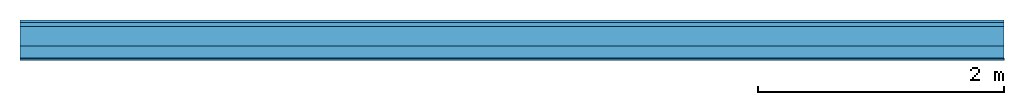
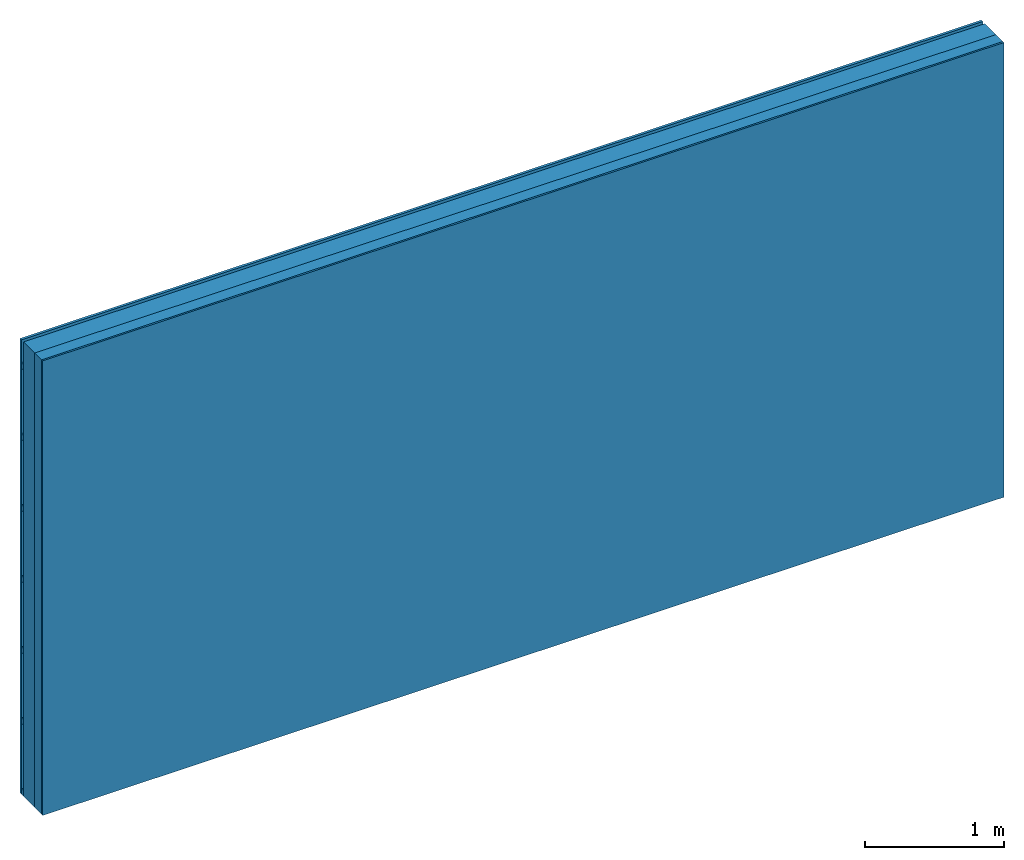
# One storey: 3 plates, 2 members, 1 element without a shape of its own.
"""IFC4 building model written with IfcOpenShell, lengths in metres."""

from ifc_helpers import new_model, si_unit, derived_unit, direction, frame, frame_2d, origin, origin_with_axes, place, context, project, spatial, rectangle, extrude, material, layer, layer_set, type_object, element, aggregate, save


model = new_model("IFC4")

# Units and contexts
plan_context = context("Plan", 3, precision=1e-05, world=origin(), true_north=direction((0.0, 1.0)))
model_context = context("Model", 3, precision=1e-05, world=origin(), true_north=direction((0.0, 1.0)))
ifc_project = project(units=[si_unit("LENGTHUNIT", "METRE"), derived_unit("SOUNDPRESSUREUNIT", [(si_unit("PRESSUREUNIT", "PASCAL", prefix="MICRO"), 0)]), si_unit("ENERGYUNIT", "JOULE", prefix="MEGA"), si_unit("MASSUNIT", "GRAM", prefix="KILO"), derived_unit("THERMALTRANSMITTANCEUNIT", [(si_unit("POWERUNIT", "WATT"), 1), (si_unit("AREAUNIT", "SQUARE_METRE"), -1), (si_unit("THERMODYNAMICTEMPERATUREUNIT", "KELVIN"), -1)]), derived_unit("AREADENSITYUNIT", [(si_unit("MASSUNIT", "GRAM", prefix="KILO"), 1), (si_unit("AREAUNIT", "SQUARE_METRE"), -1)]), derived_unit("USERDEFINED", [(si_unit("ENERGYUNIT", "JOULE", prefix="MEGA"), 1), (si_unit("AREAUNIT", "SQUARE_METRE"), -1)])], contexts=[plan_context, model_context])

# Site, building, storey
site = spatial("IfcSite", under=ifc_project)
building_placement = place(None, origin())
building = spatial("IfcBuilding", under=site, at=building_placement)
storey_placement = place(building_placement, origin())
storey = spatial("IfcBuildingStorey", under=building, at=storey_placement)

# Wall, members, plates
ifc_material_1 = material(Name="Wood cladding horizontal, closed")
ifc_layer_1 = layer(ifc_material_1, 0.022, Name="Cover 1st layer")
ifc_layer_2 = layer(None, 0.03, Name="Battens / profiles (ventilation)")
ifc_material_2 = material(Category="10.009")
ifc_layer_3 = layer(ifc_material_2, 0.16, Name="outside 2nd layer")
ifc_material_3 = material(Name="of the art")
ifc_layer_4 = layer(ifc_material_3, 0.0, Name="Bond")
ifc_layer_5 = layer(None, 0.1, Name="Support")
ifc_layer_6 = layer(ifc_material_3, 0.0, Name="Bond")
ifc_material_4 = material(Category="03.007")
ifc_layer_7 = layer(ifc_material_4, 0.015, Name="1st layer")
ifc_layer_set = layer_set([ifc_layer_1, ifc_layer_2, ifc_layer_3, ifc_layer_4, ifc_layer_5, ifc_layer_6, ifc_layer_7])
wall_type = type_object("IfcWallType", Name="D0935", PredefinedType="NOTDEFINED", material=ifc_layer_set)
wall_placement = place(None, frame((0.0, 0.0, 0.0), z_axis=(0.0, -1.0, 0.0), x_axis=(1.0, 0.0, 0.0)))
wall = element("IfcWall", 1, at=wall_placement, inside=storey, type_object=wall_type, material=ifc_layer_set, Name="Wall #1")
ifc_material_5 = material()
member_1_placement = place(wall_placement, origin())
member_1 = element("IfcMember", 2, at=member_1_placement, material=ifc_material_5, Name="Battens / profiles (ventilation)", context=plan_context, shape_type="SweptSolid", body=[
    extrude(rectangle(XDim=0.05, YDim=0.03, at=frame_2d((0.025, 0.015), x_axis=(1.0, 0.0))), frame((0.0, 0.0, 0.022), z_axis=(1.0, 0.0, 0.0), x_axis=(0.0, 1.0, 0.0)), (0.0, 0.0, 1.0), 8.0),
    extrude(rectangle(XDim=0.05, YDim=0.03, at=frame_2d((0.025, 0.015), x_axis=(1.0, 0.0))), frame((0.0, 0.625, 0.022), z_axis=(1.0, 0.0, 0.0), x_axis=(0.0, 1.0, 0.0)), (0.0, 0.0, 1.0), 8.0),
    extrude(rectangle(XDim=0.05, YDim=0.03, at=frame_2d((0.025, 0.015), x_axis=(1.0, 0.0))), frame((0.0, 1.25, 0.022), z_axis=(1.0, 0.0, 0.0), x_axis=(0.0, 1.0, 0.0)), (0.0, 0.0, 1.0), 8.0),
    extrude(rectangle(XDim=0.05, YDim=0.03, at=frame_2d((0.025, 0.015), x_axis=(1.0, 0.0))), frame((0.0, 1.875, 0.022), z_axis=(1.0, 0.0, 0.0), x_axis=(0.0, 1.0, 0.0)), (0.0, 0.0, 1.0), 8.0),
    extrude(rectangle(XDim=0.05, YDim=0.03, at=frame_2d((0.025, 0.015), x_axis=(1.0, 0.0))), frame((0.0, 2.5, 0.022), z_axis=(1.0, 0.0, 0.0), x_axis=(0.0, 1.0, 0.0)), (0.0, 0.0, 1.0), 8.0),
    extrude(rectangle(XDim=0.05, YDim=0.03, at=frame_2d((0.025, 0.015), x_axis=(1.0, 0.0))), frame((0.0, 3.125, 0.022), z_axis=(1.0, 0.0, 0.0), x_axis=(0.0, 1.0, 0.0)), (0.0, 0.0, 1.0), 8.0),
    extrude(rectangle(XDim=0.05, YDim=0.03, at=frame_2d((0.025, 0.015), x_axis=(1.0, 0.0))), frame((0.0, 3.75, 0.022), z_axis=(1.0, 0.0, 0.0), x_axis=(0.0, 1.0, 0.0)), (0.0, 0.0, 1.0), 8.0),
])
ifc_material_6 = material()
member_2_placement = place(wall_placement, origin())
member_2 = element("IfcMember", 3, at=member_2_placement, material=ifc_material_6, Name="Support", context=plan_context, shape_type="SweptSolid", body=[
    extrude(rectangle(XDim=1.0, YDim=0.1, at=frame_2d((0.5, 0.05), x_axis=(1.0, 0.0))), frame((0.0, 4.0, 0.212), z_axis=(0.0, -1.0, 0.0), x_axis=(1.0, 0.0, 0.0)), (0.0, 0.0, 1.0), 4.0),
    extrude(rectangle(XDim=1.0, YDim=0.1, at=frame_2d((0.5, 0.05), x_axis=(1.0, 0.0))), frame((1.0, 4.0, 0.212), z_axis=(0.0, -1.0, 0.0), x_axis=(1.0, 0.0, 0.0)), (0.0, 0.0, 1.0), 4.0),
    extrude(rectangle(XDim=1.0, YDim=0.1, at=frame_2d((0.5, 0.05), x_axis=(1.0, 0.0))), frame((2.0, 4.0, 0.212), z_axis=(0.0, -1.0, 0.0), x_axis=(1.0, 0.0, 0.0)), (0.0, 0.0, 1.0), 4.0),
    extrude(rectangle(XDim=1.0, YDim=0.1, at=frame_2d((0.5, 0.05), x_axis=(1.0, 0.0))), frame((3.0, 4.0, 0.212), z_axis=(0.0, -1.0, 0.0), x_axis=(1.0, 0.0, 0.0)), (0.0, 0.0, 1.0), 4.0),
    extrude(rectangle(XDim=1.0, YDim=0.1, at=frame_2d((0.5, 0.05), x_axis=(1.0, 0.0))), frame((4.0, 4.0, 0.212), z_axis=(0.0, -1.0, 0.0), x_axis=(1.0, 0.0, 0.0)), (0.0, 0.0, 1.0), 4.0),
    extrude(rectangle(XDim=1.0, YDim=0.1, at=frame_2d((0.5, 0.05), x_axis=(1.0, 0.0))), frame((5.0, 4.0, 0.212), z_axis=(0.0, -1.0, 0.0), x_axis=(1.0, 0.0, 0.0)), (0.0, 0.0, 1.0), 4.0),
    extrude(rectangle(XDim=1.0, YDim=0.1, at=frame_2d((0.5, 0.05), x_axis=(1.0, 0.0))), frame((6.0, 4.0, 0.212), z_axis=(0.0, -1.0, 0.0), x_axis=(1.0, 0.0, 0.0)), (0.0, 0.0, 1.0), 4.0),
    extrude(rectangle(XDim=1.0, YDim=0.1, at=frame_2d((0.5, 0.05), x_axis=(1.0, 0.0))), frame((7.0, 4.0, 0.212), z_axis=(0.0, -1.0, 0.0), x_axis=(1.0, 0.0, 0.0)), (0.0, 0.0, 1.0), 4.0),
])
plate_1_placement = place(wall_placement, origin())
plate_1 = element("IfcPlate", 4, at=plate_1_placement, material=ifc_material_1, Name="Cover 1st layer", context=plan_context, shape_type="SweptSolid", body=[
    extrude(rectangle(XDim=8.0, YDim=4.0, at=frame_2d((4.0, 2.0), x_axis=(1.0, 0.0))), origin_with_axes(), (0.0, 0.0, 1.0), 0.022),
])
plate_2_placement = place(wall_placement, origin())
plate_2 = element("IfcPlate", 5, at=plate_2_placement, material=ifc_material_2, Name="outside 2nd layer", context=plan_context, shape_type="SweptSolid", body=[
    extrude(rectangle(XDim=8.0, YDim=4.0, at=frame_2d((4.0, 2.0), x_axis=(1.0, 0.0))), frame((0.0, 0.0, 0.052), z_axis=(0.0, 0.0, 1.0), x_axis=(1.0, 0.0, 0.0)), (0.0, 0.0, 1.0), 0.16),
])
plate_3_placement = place(wall_placement, origin())
plate_3 = element("IfcPlate", 6, at=plate_3_placement, material=ifc_material_4, Name="1st layer", context=plan_context, shape_type="SweptSolid", body=[
    extrude(rectangle(XDim=8.0, YDim=4.0, at=frame_2d((4.0, 2.0), x_axis=(1.0, 0.0))), frame((0.0, 0.0, 0.312), z_axis=(0.0, 0.0, 1.0), x_axis=(1.0, 0.0, 0.0)), (0.0, 0.0, 1.0), 0.015),
])
aggregate(wall, [plate_1, member_1, plate_2, member_2, plate_3])

save(model, "model.ifc")
